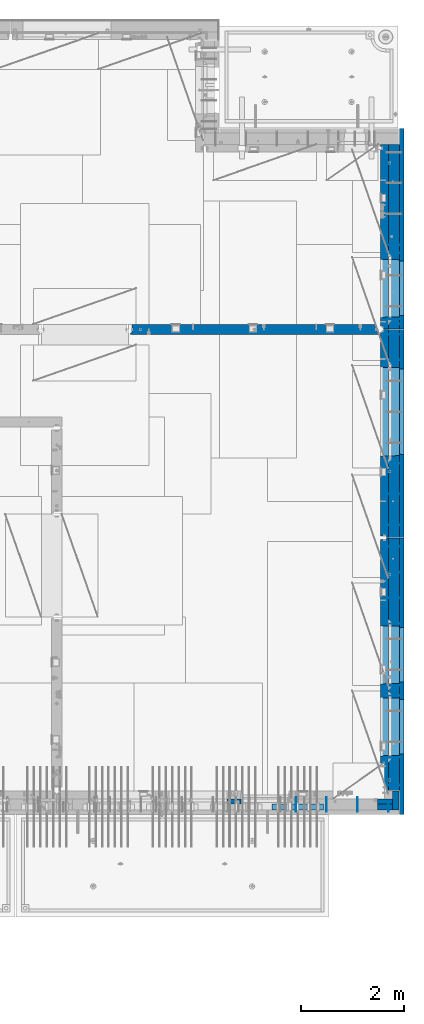
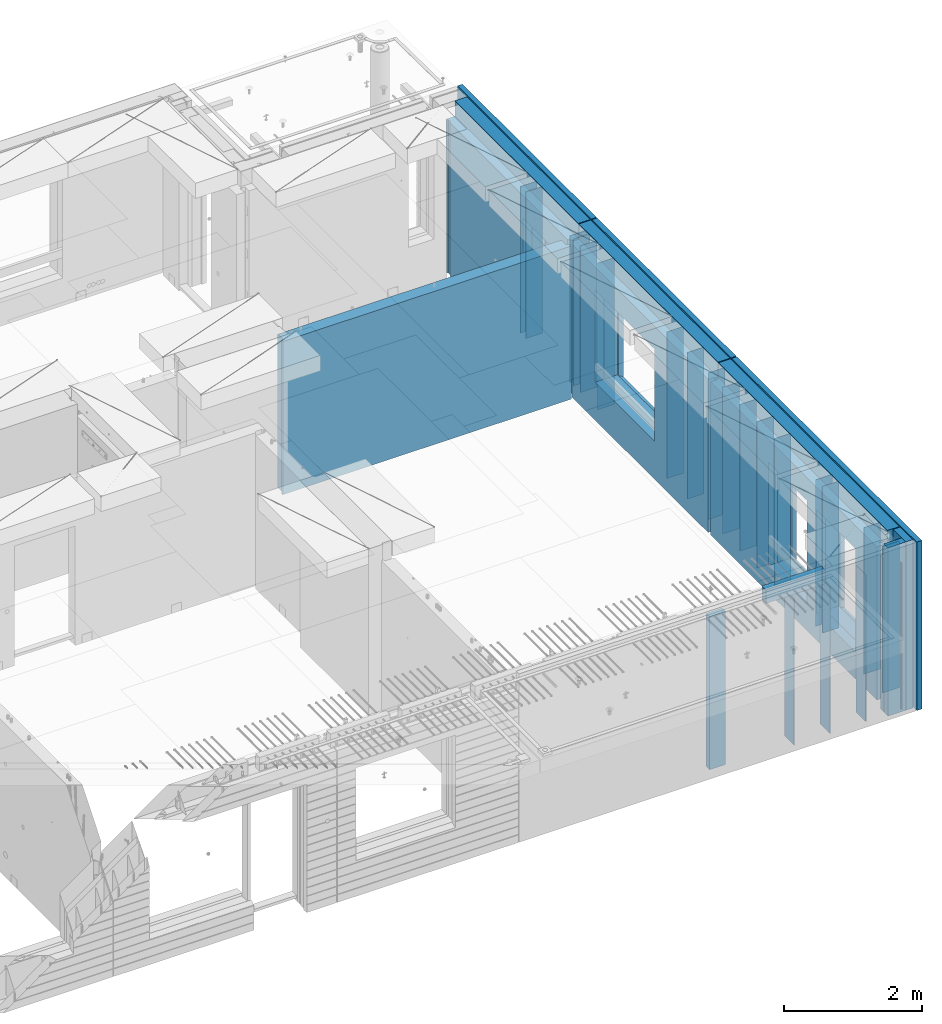
# One storey, part 233 of 341: 37 walls, 7 elements without a shape of their own.
"""IFC2X3 building model written with IfcOpenShell, lengths in millimetres."""

from ifc_helpers import new_model, si_unit, frame, origin_with_axes, place, context, subcontext, project, spatial, faceted_brep, material, type_object, element, aggregate, save


model = new_model("IFC2X3")

# Units and contexts
model_context = context("Model", 3, precision=1e-05, world=origin_with_axes())
body_context = subcontext(model_context, "Body", "Model", "MODEL_VIEW")
ifc_project = project(units=[si_unit("LENGTHUNIT", "METRE", prefix="MILLI"), si_unit("AREAUNIT", "SQUARE_METRE"), si_unit("VOLUMEUNIT", "CUBIC_METRE"), si_unit("MASSUNIT", "GRAM", prefix="KILO"), si_unit("TIMEUNIT", "SECOND"), si_unit("PLANEANGLEUNIT", "RADIAN"), si_unit("SOLIDANGLEUNIT", "STERADIAN"), si_unit("THERMODYNAMICTEMPERATUREUNIT", "DEGREE_CELSIUS"), si_unit("LUMINOUSINTENSITYUNIT", "LUMEN")], contexts=[model_context])

# Site, building, storey
site_placement = place(None, origin_with_axes())
site = spatial("IfcSite", under=ifc_project, at=site_placement, CompositionType="ELEMENT")
building_placement = place(site_placement, origin_with_axes())
building = spatial("IfcBuilding", under=site, at=building_placement, CompositionType="ELEMENT")
storey_placement = place(building_placement, origin_with_axes())
storey = spatial("IfcBuildingStorey", under=building, at=storey_placement, Name="5", CompositionType="ELEMENT", Elevation=0.0)

# Assembly, walls
assembly_1_placement = place(storey_placement, origin_with_axes())
assembly_1 = element("IfcElementAssembly", 1, at=assembly_1_placement, inside=storey, AssemblyPlace="NOTDEFINED", PredefinedType="REINFORCEMENT_UNIT")
ifc_material_1 = material(Name="Undefined")
wall_type_1 = type_object("IfcWallType", PredefinedType="NOTDEFINED")
wall_1_placement = place(assembly_1_placement, frame((35030.0, 18465.0002441406, 95115.0), z_axis=(0.0, 0.0, 1.0), x_axis=(1.0, 0.0, 0.0)))
wall_1 = element("IfcWall", 2, at=wall_1_placement, type_object=wall_type_1, material=ifc_material_1, Name="(PD)", context=body_context, shape_type="Brep", body=[
    faceted_brep([(0.0, 5.0, -1300.0), (0.0, 5.0, 1300.0), (280.0, 5.0, 1300.0), (280.0, 5.0, -1300.0), (0.0, -5.0, 1300.0), (280.0, -5.0, 1300.0), (0.0, -5.0, -1300.0), (280.0, -5.0, -1300.0)], [[[0, 1, 2, 3]], [[1, 4, 5, 2]], [[4, 6, 7, 5]], [[6, 0, 3, 7]], [[5, 7, 3, 2]], [[6, 4, 1, 0]]]),
])
wall_2_placement = place(assembly_1_placement, frame((35030.0, 17085.0002441406, 95115.0), z_axis=(0.0, 0.0, 1.0), x_axis=(1.0, 0.0, 0.0)))
wall_2 = element("IfcWall", 3, at=wall_2_placement, type_object=wall_type_1, material=ifc_material_1, Name="(PD)", context=body_context, shape_type="Brep", body=[
    faceted_brep([(0.0, 5.0, -1300.0), (0.0, 5.0, 1300.0), (280.0, 5.0, 1300.0), (280.0, 5.0, -1300.0), (0.0, -5.0, 1300.0), (280.0, -5.0, 1300.0), (0.0, -5.0, -1300.0), (280.0, -5.0, -1300.0)], [[[0, 1, 2, 3]], [[1, 4, 5, 2]], [[4, 6, 7, 5]], [[6, 0, 3, 7]], [[5, 7, 3, 2]], [[6, 4, 1, 0]]]),
])
wall_3_placement = place(assembly_1_placement, frame((35030.0, 17185.0002441406, 95115.0), z_axis=(0.0, 0.0, 1.0), x_axis=(1.0, 0.0, 0.0)))
wall_3 = element("IfcWall", 4, at=wall_3_placement, type_object=wall_type_1, material=ifc_material_1, Name="(PD)", context=body_context, shape_type="Brep", body=[
    faceted_brep([(0.0, 5.0, -1300.0), (0.0, 5.0, 1300.0), (280.0, 5.0, 1300.0), (280.0, 5.0, -1300.0), (0.0, -5.0, 1300.0), (280.0, -5.0, 1300.0), (0.0, -5.0, -1300.0), (280.0, -5.0, -1300.0)], [[[0, 1, 2, 3]], [[1, 4, 5, 2]], [[4, 6, 7, 5]], [[6, 0, 3, 7]], [[5, 7, 3, 2]], [[6, 4, 1, 0]]]),
])
wall_4_placement = place(assembly_1_placement, frame((35030.0, 18625.0002441406, 95115.0), z_axis=(0.0, 0.0, 1.0), x_axis=(1.0, 0.0, 0.0)))
wall_4 = element("IfcWall", 5, at=wall_4_placement, type_object=wall_type_1, material=ifc_material_1, Name="(PD)", context=body_context, shape_type="Brep", body=[
    faceted_brep([(0.0, 5.0, -1300.0), (0.0, 5.0, 1300.0), (280.0, 5.0, 1300.0), (280.0, 5.0, -1300.0), (0.0, -5.0, 1300.0), (280.0, -5.0, 1300.0), (0.0, -5.0, -1300.0), (280.0, -5.0, -1300.0)], [[[0, 1, 2, 3]], [[1, 4, 5, 2]], [[4, 6, 7, 5]], [[6, 0, 3, 7]], [[5, 7, 3, 2]], [[6, 4, 1, 0]]]),
])

assembly_2_placement = place(storey_placement, origin_with_axes())
assembly_2 = element("IfcElementAssembly", 6, at=assembly_2_placement, inside=storey, AssemblyPlace="NOTDEFINED", PredefinedType="REINFORCEMENT_UNIT")
wall_5_placement = place(assembly_2_placement, frame((35060.0, 7780.0, 95115.0), z_axis=(0.0, 0.0, 1.0), x_axis=(0.0, -1.0, 0.0)))
wall_5 = element("IfcWall", 7, at=wall_5_placement, type_object=wall_type_1, material=ifc_material_1, Name="(PD)", context=body_context, shape_type="Brep", body=[
    faceted_brep([(0.0, 5.0, -1300.0), (0.0, 5.0, 1300.0), (180.0, 5.0, 1300.0), (180.0, 5.0, -1300.0), (0.0, -5.0, 1300.0), (180.0, -5.0, 1300.0), (0.0, -5.0, -1300.0), (180.0, -5.0, -1300.0)], [[[0, 1, 2, 3]], [[1, 4, 5, 2]], [[4, 6, 7, 5]], [[6, 0, 3, 7]], [[5, 7, 3, 2]], [[6, 4, 1, 0]]]),
])
wall_6_placement = place(assembly_2_placement, frame((34460.0, 7880.0, 95115.0), z_axis=(0.0, 0.0, 1.0), x_axis=(0.0, -1.0, 0.0)))
wall_6 = element("IfcWall", 8, at=wall_6_placement, type_object=wall_type_1, material=ifc_material_1, Name="(PD)", context=body_context, shape_type="Brep", body=[
    faceted_brep([(0.0, 5.0, -1300.0), (0.0, 5.0, 1300.0), (280.0, 5.0, 1300.0), (280.0, 5.0, -1300.0), (0.0, -5.0, 1300.0), (280.0, -5.0, 1300.0), (0.0, -5.0, -1300.0), (280.0, -5.0, -1300.0)], [[[0, 1, 2, 3]], [[1, 4, 5, 2]], [[4, 6, 7, 5]], [[6, 0, 3, 7]], [[5, 7, 3, 2]], [[6, 4, 1, 0]]]),
])
wall_7_placement = place(assembly_2_placement, frame((33860.0, 7880.0, 95115.0), z_axis=(0.0, 0.0, 1.0), x_axis=(0.0, -1.0, 0.0)))
wall_7 = element("IfcWall", 9, at=wall_7_placement, type_object=wall_type_1, material=ifc_material_1, Name="(PD)", context=body_context, shape_type="Brep", body=[
    faceted_brep([(0.0, 5.0, -1300.0), (0.0, 5.0, 1300.0), (280.0, 5.0, 1300.0), (280.0, 5.0, -1300.0), (0.0, -5.0, 1300.0), (280.0, -5.0, 1300.0), (0.0, -5.0, -1300.0), (280.0, -5.0, -1300.0)], [[[0, 1, 2, 3]], [[1, 4, 5, 2]], [[4, 6, 7, 5]], [[6, 0, 3, 7]], [[5, 7, 3, 2]], [[6, 4, 1, 0]]]),
])

assembly_3_placement = place(storey_placement, origin_with_axes())
assembly_3 = element("IfcElementAssembly", 10, at=assembly_3_placement, inside=storey, AssemblyPlace="NOTDEFINED", PredefinedType="REINFORCEMENT_UNIT")
wall_8_placement = place(assembly_3_placement, frame((35030.0, 12755.0002861023, 95115.0), z_axis=(0.0, 0.0, 1.0), x_axis=(1.0, 0.0, 0.0)))
wall_8 = element("IfcWall", 11, at=wall_8_placement, type_object=wall_type_1, material=ifc_material_1, Name="(PD)", context=body_context, shape_type="Brep", body=[
    faceted_brep([(0.0, 5.0, -1300.0), (0.0, 5.0, 1300.0), (280.0, 5.0, 1300.0), (280.0, 5.0, -1300.0), (0.0, -5.0, 1300.0), (280.0, -5.0, 1300.0), (0.0, -5.0, -1300.0), (280.0, -5.0, -1300.0)], [[[0, 1, 2, 3]], [[1, 4, 5, 2]], [[4, 6, 7, 5]], [[6, 0, 3, 7]], [[5, 7, 3, 2]], [[6, 4, 1, 0]]]),
])
wall_9_placement = place(assembly_3_placement, frame((35030.0, 12255.0002861023, 95115.0), z_axis=(0.0, 0.0, 1.0), x_axis=(1.0, 0.0, 0.0)))
wall_9 = element("IfcWall", 12, at=wall_9_placement, type_object=wall_type_1, material=ifc_material_1, Name="(PD)", context=body_context, shape_type="Brep", body=[
    faceted_brep([(0.0, 5.0, -1300.0), (0.0, 5.0, 1300.0), (280.0, 5.0, 1300.0), (280.0, 5.0, -1300.0), (0.0, -5.0, 1300.0), (280.0, -5.0, 1300.0), (0.0, -5.0, -1300.0), (280.0, -5.0, -1300.0)], [[[0, 1, 2, 3]], [[1, 4, 5, 2]], [[4, 6, 7, 5]], [[6, 0, 3, 7]], [[5, 7, 3, 2]], [[6, 4, 1, 0]]]),
])
wall_10_placement = place(assembly_3_placement, frame((35030.0, 11755.0002861023, 95115.0), z_axis=(0.0, 0.0, 1.0), x_axis=(1.0, 0.0, 0.0)))
wall_10 = element("IfcWall", 13, at=wall_10_placement, type_object=wall_type_1, material=ifc_material_1, Name="(PD)", context=body_context, shape_type="Brep", body=[
    faceted_brep([(0.0, 5.0, -1300.0), (0.0, 5.0, 1300.0), (280.0, 5.0, 1300.0), (280.0, 5.0, -1300.0), (0.0, -5.0, 1300.0), (280.0, -5.0, 1300.0), (0.0, -5.0, -1300.0), (280.0, -5.0, -1300.0)], [[[0, 1, 2, 3]], [[1, 4, 5, 2]], [[4, 6, 7, 5]], [[6, 0, 3, 7]], [[5, 7, 3, 2]], [[6, 4, 1, 0]]]),
])
wall_11_placement = place(assembly_3_placement, frame((35030.0, 11255.0002861023, 95115.0), z_axis=(0.0, 0.0, 1.0), x_axis=(1.0, 0.0, 0.0)))
wall_11 = element("IfcWall", 14, at=wall_11_placement, type_object=wall_type_1, material=ifc_material_1, Name="(PD)", context=body_context, shape_type="Brep", body=[
    faceted_brep([(0.0, 5.0, -1300.0), (0.0, 5.0, 1300.0), (280.0, 5.0, 1300.0), (280.0, 5.0, -1300.0), (0.0, -5.0, 1300.0), (280.0, -5.0, 1300.0), (0.0, -5.0, -1300.0), (280.0, -5.0, -1300.0)], [[[0, 1, 2, 3]], [[1, 4, 5, 2]], [[4, 6, 7, 5]], [[6, 0, 3, 7]], [[5, 7, 3, 2]], [[6, 4, 1, 0]]]),
])
wall_12_placement = place(assembly_3_placement, frame((35030.0, 8105.0, 95115.0), z_axis=(0.0, 0.0, 1.0), x_axis=(1.0, 0.0, 0.0)))
wall_12 = element("IfcWall", 15, at=wall_12_placement, type_object=wall_type_1, material=ifc_material_1, Name="(PD)", context=body_context, shape_type="Brep", body=[
    faceted_brep([(0.0, 5.0, -1300.0), (0.0, 5.0, 1300.0), (280.0, 5.0, 1300.0), (280.0, 5.0, -1300.0), (0.0, -5.0, 1300.0), (280.0, -5.0, 1300.0), (0.0, -5.0, -1300.0), (280.0, -5.0, -1300.0)], [[[0, 1, 2, 3]], [[1, 4, 5, 2]], [[4, 6, 7, 5]], [[6, 0, 3, 7]], [[5, 7, 3, 2]], [[6, 4, 1, 0]]]),
])
wall_13_placement = place(assembly_3_placement, frame((35030.0, 8115.0, 95115.0), z_axis=(0.0, 0.0, 1.0), x_axis=(1.0, 0.0, 0.0)))
wall_13 = element("IfcWall", 16, at=wall_13_placement, type_object=wall_type_1, material=ifc_material_1, Name="(PD)", context=body_context, shape_type="Brep", body=[
    faceted_brep([(0.0, 5.0, -1300.0), (0.0, 5.0, 1300.0), (280.0, 5.0, 1300.0), (280.0, 5.0, -1300.0), (0.0, -5.0, 1300.0), (280.0, -5.0, 1300.0), (0.0, -5.0, -1300.0), (280.0, -5.0, -1300.0)], [[[0, 1, 2, 3]], [[1, 4, 5, 2]], [[4, 6, 7, 5]], [[6, 0, 3, 7]], [[5, 7, 3, 2]], [[6, 4, 1, 0]]]),
])
wall_14_placement = place(assembly_3_placement, frame((35030.0, 9855.00028610229, 95115.0), z_axis=(0.0, 0.0, 1.0), x_axis=(1.0, 0.0, 0.0)))
wall_14 = element("IfcWall", 17, at=wall_14_placement, type_object=wall_type_1, material=ifc_material_1, Name="(PD)", context=body_context, shape_type="Brep", body=[
    faceted_brep([(0.0, 5.0, -1300.0), (0.0, 5.0, 1300.0), (280.0, 5.0, 1300.0), (280.0, 5.0, -1300.0), (0.0, -5.0, 1300.0), (280.0, -5.0, 1300.0), (0.0, -5.0, -1300.0), (280.0, -5.0, -1300.0)], [[[0, 1, 2, 3]], [[1, 4, 5, 2]], [[4, 6, 7, 5]], [[6, 0, 3, 7]], [[5, 7, 3, 2]], [[6, 4, 1, 0]]]),
])
wall_15_placement = place(assembly_3_placement, frame((35030.0, 10055.0002861023, 95115.0), z_axis=(0.0, 0.0, 1.0), x_axis=(1.0, 0.0, 0.0)))
wall_15 = element("IfcWall", 18, at=wall_15_placement, type_object=wall_type_1, material=ifc_material_1, Name="(PD)", context=body_context, shape_type="Brep", body=[
    faceted_brep([(0.0, 5.0, -1300.0), (0.0, 5.0, 1300.0), (280.0, 5.0, 1300.0), (280.0, 5.0, -1300.0), (0.0, -5.0, 1300.0), (280.0, -5.0, 1300.0), (0.0, -5.0, -1300.0), (280.0, -5.0, -1300.0)], [[[0, 1, 2, 3]], [[1, 4, 5, 2]], [[4, 6, 7, 5]], [[6, 0, 3, 7]], [[5, 7, 3, 2]], [[6, 4, 1, 0]]]),
])

assembly_4_placement = place(storey_placement, origin_with_axes())
assembly_4 = element("IfcElementAssembly", 19, at=assembly_4_placement, inside=storey, AssemblyPlace="NOTDEFINED", PredefinedType="REINFORCEMENT_UNIT")
wall_16_placement = place(assembly_4_placement, frame((35030.0, 13175.0002861023, 95115.0), z_axis=(0.0, 0.0, 1.0), x_axis=(1.0, 0.0, 0.0)))
wall_16 = element("IfcWall", 20, at=wall_16_placement, type_object=wall_type_1, material=ifc_material_1, Name="(PD)", context=body_context, shape_type="Brep", body=[
    faceted_brep([(0.0, 5.0, -1300.0), (0.0, 5.0, 1300.0), (280.0, 5.0, 1300.0), (280.0, 5.0, -1300.0), (0.0, -5.0, 1300.0), (280.0, -5.0, 1300.0), (0.0, -5.0, -1300.0), (280.0, -5.0, -1300.0)], [[[0, 1, 2, 3]], [[1, 4, 5, 2]], [[4, 6, 7, 5]], [[6, 0, 3, 7]], [[5, 7, 3, 2]], [[6, 4, 1, 0]]]),
])
wall_17_placement = place(assembly_4_placement, frame((35030.0, 13775.0002861023, 95115.0), z_axis=(0.0, 0.0, 1.0), x_axis=(1.0, 0.0, 0.0)))
wall_17 = element("IfcWall", 21, at=wall_17_placement, type_object=wall_type_1, material=ifc_material_1, Name="(PD)", context=body_context, shape_type="Brep", body=[
    faceted_brep([(0.0, 5.0, -1300.0), (0.0, 5.0, 1300.0), (280.0, 5.0, 1300.0), (280.0, 5.0, -1300.0), (0.0, -5.0, 1300.0), (280.0, -5.0, 1300.0), (0.0, -5.0, -1300.0), (280.0, -5.0, -1300.0)], [[[0, 1, 2, 3]], [[1, 4, 5, 2]], [[4, 6, 7, 5]], [[6, 0, 3, 7]], [[5, 7, 3, 2]], [[6, 4, 1, 0]]]),
])
wall_18_placement = place(assembly_4_placement, frame((35030.0, 16885.0002861023, 95115.0), z_axis=(0.0, 0.0, 1.0), x_axis=(1.0, 0.0, 0.0)))
wall_18 = element("IfcWall", 22, at=wall_18_placement, type_object=wall_type_1, material=ifc_material_1, Name="(PD)", context=body_context, shape_type="Brep", body=[
    faceted_brep([(0.0, 5.0, -1300.0), (0.0, 5.0, 1300.0), (280.0, 5.0, 1300.0), (280.0, 5.0, -1300.0), (0.0, -5.0, 1300.0), (280.0, -5.0, 1300.0), (0.0, -5.0, -1300.0), (280.0, -5.0, -1300.0)], [[[0, 1, 2, 3]], [[1, 4, 5, 2]], [[4, 6, 7, 5]], [[6, 0, 3, 7]], [[5, 7, 3, 2]], [[6, 4, 1, 0]]]),
])
wall_19_placement = place(assembly_4_placement, frame((35030.0, 16385.0002861023, 95115.0), z_axis=(0.0, 0.0, 1.0), x_axis=(1.0, 0.0, 0.0)))
wall_19 = element("IfcWall", 23, at=wall_19_placement, type_object=wall_type_1, material=ifc_material_1, Name="(PD)", context=body_context, shape_type="Brep", body=[
    faceted_brep([(0.0, 5.0, -1300.0), (0.0, 5.0, 1300.0), (280.0, 5.0, 1300.0), (280.0, 5.0, -1300.0), (0.0, -5.0, 1300.0), (280.0, -5.0, 1300.0), (0.0, -5.0, -1300.0), (280.0, -5.0, -1300.0)], [[[0, 1, 2, 3]], [[1, 4, 5, 2]], [[4, 6, 7, 5]], [[6, 0, 3, 7]], [[5, 7, 3, 2]], [[6, 4, 1, 0]]]),
])

# Wall
wall_20_placement = place(assembly_2_placement, frame((33260.0, 7880.0, 95115.0), z_axis=(0.0, 0.0, 1.0), x_axis=(0.0, -1.0, 0.0)))
wall_20 = element("IfcWall", 24, at=wall_20_placement, type_object=wall_type_1, material=ifc_material_1, Name="(PD)", context=body_context, shape_type="Brep", body=[
    faceted_brep([(0.0, 5.0, -1300.0), (0.0, 5.0, 1300.0), (280.0, 5.0, 1300.0), (280.0, 5.0, -1300.0), (0.0, -5.0, 1300.0), (280.0, -5.0, 1300.0), (0.0, -5.0, -1300.0), (280.0, -5.0, -1300.0)], [[[0, 1, 2, 3]], [[1, 4, 5, 2]], [[4, 6, 7, 5]], [[6, 0, 3, 7]], [[5, 7, 3, 2]], [[6, 4, 1, 0]]]),
])

wall_21_placement = place(assembly_3_placement, frame((35030.0, 8655.0, 95115.0), z_axis=(0.0, 0.0, 1.0), x_axis=(1.0, 0.0, 0.0)))
wall_21 = element("IfcWall", 25, at=wall_21_placement, type_object=wall_type_1, material=ifc_material_1, Name="(PD)", context=body_context, shape_type="Brep", body=[
    faceted_brep([(0.0, 5.0, -1300.0), (0.0, 5.0, 1300.0), (280.0, 5.0, 1300.0), (280.0, 5.0, -1300.0), (0.0, -5.0, 1300.0), (280.0, -5.0, 1300.0), (0.0, -5.0, -1300.0), (280.0, -5.0, -1300.0)], [[[0, 1, 2, 3]], [[1, 4, 5, 2]], [[4, 6, 7, 5]], [[6, 0, 3, 7]], [[5, 7, 3, 2]], [[6, 4, 1, 0]]]),
])

wall_22_placement = place(assembly_4_placement, frame((35030.0, 14375.0002861023, 95115.0), z_axis=(0.0, 0.0, 1.0), x_axis=(1.0, 0.0, 0.0)))
wall_22 = element("IfcWall", 26, at=wall_22_placement, type_object=wall_type_1, material=ifc_material_1, Name="(PD)", context=body_context, shape_type="Brep", body=[
    faceted_brep([(0.0, 5.0, -1300.0), (0.0, 5.0, 1300.0), (280.0, 5.0, 1300.0), (280.0, 5.0, -1300.0), (0.0, -5.0, 1300.0), (280.0, -5.0, 1300.0), (0.0, -5.0, -1300.0), (280.0, -5.0, -1300.0)], [[[0, 1, 2, 3]], [[1, 4, 5, 2]], [[4, 6, 7, 5]], [[6, 0, 3, 7]], [[5, 7, 3, 2]], [[6, 4, 1, 0]]]),
])

# Assembly, wall
assembly_5_placement = place(storey_placement, origin_with_axes())
assembly_5 = element("IfcElementAssembly", 27, at=assembly_5_placement, inside=storey, AssemblyPlace="NOTDEFINED", PredefinedType="REINFORCEMENT_UNIT")
ifc_material_2 = material(Name="CONCRETE/C25/30")
wall_type_2 = type_object("IfcWallType", PredefinedType="NOTDEFINED")
wall_23_placement = place(assembly_5_placement, frame((30040.0, 16980.0002441406, 95112.5), z_axis=(0.0, 0.0, 1.0), x_axis=(1.0, 0.0, 0.0)))
wall_23 = element("IfcWall", 28, at=wall_23_placement, type_object=wall_type_2, material=ifc_material_2, context=body_context, shape_type="Brep", body=[
    faceted_brep([(4785.0, 100.0, 1357.5), (4785.0, -30.0, 1357.5), (4785.0, -30.0, -1357.5), (4785.0, 100.0, -1357.5), (4840.0, -60.0, 1357.5), (4840.0, -60.0, -1357.5), (30.0003214753524, 100.0, 1357.5), (30.0003214753524, 100.0, -1357.5), (30.0003214753524, -57.0, -1357.5), (30.0003214753524, -57.0, 1357.5), (0.0, -70.0001393059865, -1357.5), (0.0, -70.0001393059865, 1357.5), (0.0, -100.0, -1357.5), (0.0, -100.0, 1357.5), (4840.0, -100.0, -1357.5), (4840.0, -100.0, 1357.5)], [[[0, 1, 2, 3]], [[4, 5, 2, 1]], [[6, 7, 8, 9]], [[9, 8, 10, 11]], [[12, 13, 11, 10]], [[13, 12, 14, 15]], [[0, 6, 9, 11, 13, 15, 4, 1]], [[7, 6, 0, 3]], [[14, 12, 10, 8, 7, 3, 2, 5]], [[15, 14, 5, 4]]]),
])
aggregate(assembly_5, [wall_23])

# Assemblies, wall
assembly_6_placement = place(storey_placement, origin_with_axes())
assembly_6 = element("IfcElementAssembly", 29, at=assembly_6_placement, inside=storey, AssemblyPlace="NOTDEFINED", PredefinedType="REINFORCEMENT_UNIT")
assembly_7_placement = place(assembly_6_placement, origin_with_axes())
assembly_7 = element("IfcElementAssembly", 30, at=assembly_7_placement, Name="Steel Assembly", AssemblyPlace="NOTDEFINED", PredefinedType="NOTDEFINED")
aggregate(assembly_6, [assembly_7])
ifc_material_3 = material()
wall_type_3 = type_object("IfcWallType", PredefinedType="NOTDEFINED")
wall_24_placement = place(assembly_7_placement, frame((32799.9998568133, 7690.00021946163, 96590.0), z_axis=(0.0, 0.0, 1.0), x_axis=(1.0, 0.0, 0.0)))
wall_24 = element("IfcWall", 31, at=wall_24_placement, type_object=wall_type_3, material=ifc_material_3, context=body_context, shape_type="Brep", body=[
    faceted_brep([(0.0, 60.0, -120.0), (0.0, 60.0, 120.0), (1000.0, 60.0, 120.0), (1000.0, 60.0, -120.0), (0.0, -60.0, 120.0), (1000.0, -60.0, 120.0), (0.0, -60.0, -120.0), (1000.0, -60.0, -120.0)], [[[0, 1, 2, 3]], [[1, 4, 5, 2]], [[4, 6, 7, 5]], [[6, 0, 3, 7]], [[5, 7, 3, 2]], [[6, 4, 1, 0]]]),
])
aggregate(assembly_7, [wall_24])

# Wall
ifc_material_4 = material(Name="COS5gt")
wall_type_4 = type_object("IfcWallType", PredefinedType="NOTDEFINED")
wall_25_placement = place(assembly_1_placement, frame((35170.0, 20575.0002441406, 95247.5), z_axis=(0.0, 0.0, 1.0), x_axis=(0.0, -1.0, 0.0)))
wall_25 = element("IfcWall", 32, at=wall_25_placement, type_object=wall_type_4, material=ifc_material_4, context=body_context, shape_type="Brep", body=[
    faceted_brep([(0.0, 90.0, 1492.5), (3585.0, 90.0, 1492.5), (3585.0, 90.0, 1442.5), (0.0, 90.0, 1442.5), (0.0, -110.0, 1492.5), (3585.0, -110.0, 1492.5), (3585.0, 110.0, 1442.5), (3585.0, -110.0, -1492.5), (3585.0, 90.0, -1492.5), (3585.0, 90.0, -1442.5), (3585.0, 110.0, -1442.5), (0.0, 110.0, 1442.5), (0.0, 90.0, -1492.5), (0.0, -110.0, -1492.5), (0.0, 110.0, -1442.5), (0.0, 90.0, -1442.5), (2239.99987343476, 110.0, -807.5), (2269.99987343476, 110.0, -807.5), (3319.99987343476, 110.0, -807.5), (3349.99987343476, 110.0, -807.5), (3349.99987343476, 110.0, -802.5), (3349.99987343476, 110.0, 807.5), (2239.99987343476, 110.0, 807.5), (2239.99987343476, 110.0, -802.5), (3355.94581938071, -110.0, -813.445945945947), (3355.94581938071, -110.0, 813.445945945947), (2234.05392748882, -110.0, -813.445945945947), (2234.05392748882, -110.0, 813.445945945947)], [[[0, 1, 2, 3]], [[4, 5, 1, 0]], [[6, 2, 1, 5, 7, 8, 9, 10]], [[11, 3, 2, 6]], [[12, 13, 4, 0, 3, 11, 14, 15]], [[7, 13, 12, 8]], [[15, 9, 8, 12]], [[14, 10, 9, 15]], [[11, 6, 10, 14], [16, 17, 18, 19, 20, 21, 22, 23]], [[20, 19, 24, 25, 21]], [[18, 17, 16, 26, 24, 19]], [[23, 22, 27, 26, 16]], [[21, 25, 27, 22]], [[4, 13, 7, 5], [24, 26, 27, 25]]]),
])

wall_26_placement = place(assembly_3_placement, frame((35170.0, 12920.0002861023, 95247.5), z_axis=(0.0, 0.0, 1.0), x_axis=(0.0, -1.0, 0.0)))
wall_26 = element("IfcWall", 33, at=wall_26_placement, type_object=wall_type_4, material=ifc_material_4, context=body_context, shape_type="Brep", body=[
    faceted_brep([(0.0, 90.0, 1492.5), (4905.00028610229, 90.0, 1492.5), (4905.00028610229, 90.0, 1442.5), (-0.25, 90.0, 1442.5), (0.0, -110.0, 1492.5), (4905.00028610229, -110.0, 1492.5), (4905.00028610229, 110.0, 1442.5), (4905.00028610229, -110.0, -1492.5), (4905.00028610229, 90.0, -1492.5), (4905.00028610229, 90.0, -1442.5), (4905.00028610229, 110.0, -1442.5), (-0.25, 110.0, 1442.5), (0.0, 90.0, -1492.5), (0.0, -110.0, -1492.5), (-0.25, 110.0, -1442.5), (-0.25, 90.0, -1442.5), (3115.00024333302, 110.0, -1007.5), (3145.00024333302, 110.0, -1007.5), (4195.00024333302, 110.0, -1007.5), (4225.00024333302, 110.0, -1007.5), (4225.00024333302, 110.0, -1002.5), (4225.00024333302, 110.0, 807.5), (3115.00024333302, 110.0, 807.5), (3115.00024333302, 110.0, -1002.5), (1715.00062480275, 110.0, -1007.5), (1745.00062480275, 110.0, -1007.5), (2795.00062480275, 110.0, -1007.5), (2825.00062480275, 110.0, -1007.5), (2825.00062480275, 110.0, -1002.5), (2825.00062480275, 110.0, 807.5), (1715.00062480275, 110.0, 807.5), (1715.00062480275, 110.0, -1002.5), (4230.94618927897, -110.0, -1013.44594594595), (4230.94618927897, -110.0, 813.445945945947), (3109.05429738708, -110.0, -1013.44594594595), (3109.05429738708, -110.0, 813.445945945947), (2830.9465707487, -110.0, -1013.44594594595), (1709.0546788568, -110.0, -1013.44594594595), (1709.0546788568, -110.0, 813.445945945947), (2830.9465707487, -110.0, 813.445945945947)], [[[0, 1, 2, 3]], [[4, 5, 1, 0]], [[6, 2, 1, 5, 7, 8, 9, 10]], [[11, 3, 2, 6]], [[12, 13, 4, 0, 3, 11, 14, 15]], [[7, 13, 12, 8]], [[15, 9, 8, 12]], [[14, 10, 9, 15]], [[11, 6, 10, 14], [16, 17, 18, 19, 20, 21, 22, 23], [24, 25, 26, 27, 28, 29, 30, 31]], [[20, 19, 32, 33, 21]], [[18, 17, 16, 34, 32, 19]], [[23, 22, 35, 34, 16]], [[21, 33, 35, 22]], [[4, 13, 7, 5], [32, 34, 35, 33], [36, 37, 38, 39]], [[26, 25, 24, 37, 36, 27]], [[31, 30, 38, 37, 24]], [[29, 39, 38, 30]], [[28, 27, 36, 39, 29]]]),
])

wall_27_placement = place(assembly_4_placement, frame((35170.0, 16980.0002861023, 95247.5), z_axis=(0.0, 0.0, 1.0), x_axis=(0.0, -1.0, 0.0)))
wall_27 = element("IfcWall", 34, at=wall_27_placement, type_object=wall_type_4, material=ifc_material_4, context=body_context, shape_type="Brep", body=[
    faceted_brep([(1409.0, 90.0, -1492.5), (1409.0, 90.0, -1442.5), (4045.0, 90.0, -1442.5), (4045.0, 90.0, -1492.5), (5.0, 110.0, -1492.5), (5.0, -110.0, -1492.5), (5.0, -110.0, 1492.5), (5.00004196166992, 90.0, 1492.5), (5.00004196166992, 90.0, 1442.5), (5.00004196166992, 110.0, 1442.5), (4045.0, -110.0, -1492.5), (4045.0, -110.0, 1492.5), (2460.94588410319, -110.0, -813.445945945947), (739.053992211293, -110.0, -813.445945945947), (739.053992211293, -110.0, 813.445945945947), (2460.94588410319, -110.0, 813.445945945947), (2454.99993815724, 110.0, 807.5), (744.99993815724, 110.0, 807.5), (2454.99993815724, 110.0, -802.5), (2454.99993815724, 110.0, -807.5), (2424.99993815724, 110.0, -807.5), (774.99993815724, 110.0, -807.5), (744.99993815724, 110.0, -807.5), (744.99993815724, 110.0, -802.5), (4045.0, 110.0, 1442.5), (4045.0, 110.0, -1442.5), (1409.0, 110.0, -1442.5), (1409.0, 110.0, -1492.5), (4045.0, 90.0, 1442.5), (4045.0, 90.0, 1492.5)], [[[0, 1, 2, 3]], [[4, 5, 6, 7, 8, 9]], [[6, 5, 10, 11], [12, 13, 14, 15]], [[16, 15, 14, 17]], [[18, 19, 12, 15, 16]], [[20, 21, 22, 13, 12, 19]], [[23, 17, 14, 13, 22]], [[4, 9, 24, 25, 26, 27], [22, 21, 20, 19, 18, 16, 17, 23]], [[3, 10, 5, 4, 27, 0]], [[26, 1, 0, 27]], [[25, 2, 1, 26]], [[24, 28, 29, 11, 10, 3, 2, 25]], [[9, 8, 28, 24]], [[7, 29, 28, 8]], [[6, 11, 29, 7]]]),
])

ifc_material_5 = material(Name="CONCRETE/C30/37")
wall_type_5 = type_object("IfcWallType", PredefinedType="NOTDEFINED")
wall_28_placement = place(assembly_1_placement, frame((35322.5, 20432.0002441406, 95247.5), z_axis=(0.0, 0.0, 1.0), x_axis=(0.0, -1.0, 0.0)))
wall_28 = element("IfcWall", 35, at=wall_28_placement, type_object=wall_type_5, material=ifc_material_5, context=body_context, shape_type="Brep", body=[
    faceted_brep([(-453.0, -42.5, -1492.5), (-453.0, -42.5, 1492.5), (-453.0, 42.5, 1492.5), (-453.0, 42.5, -1492.5), (3442.0, 42.5, -1492.5), (3442.0, -42.5, -1492.5), (3442.0, -42.5, 1492.5), (3176.99987343476, -42.5, 782.5), (3176.99987343476, -42.5, -807.5), (2126.99987343476, -42.5, -807.5), (2126.99987343476, -42.5, 782.5), (2126.99987343476, -42.5, 787.5), (3176.99987343476, -42.5, 787.5), (2126.99987343476, 42.5, 782.5), (3176.99987343476, 42.5, 782.5), (3186.99987343476, 42.5, 782.5), (2116.99987343476, 42.5, 782.5), (3186.99987343476, 42.5, -857.5), (2116.99987343476, 42.5, -857.5), (3442.0, 42.5, 1492.5)], [[[0, 1, 2, 3]], [[0, 3, 4, 5]], [[1, 0, 5, 6], [7, 8, 9, 10, 11, 12]], [[13, 14, 15, 12, 11, 16]], [[17, 8, 7, 12, 15]], [[18, 9, 8, 17]], [[16, 11, 10, 9, 18]], [[3, 2, 19, 4], [17, 15, 14, 13, 16, 18]], [[6, 5, 4, 19]], [[2, 1, 6, 19]]]),
])

wall_29_placement = place(assembly_3_placement, frame((35322.5, 12920.2502861023, 95247.5), z_axis=(0.0, 0.0, 1.0), x_axis=(0.0, -1.0, 0.0)))
wall_29 = element("IfcWall", 36, at=wall_29_placement, type_object=wall_type_5, material=ifc_material_5, context=body_context, shape_type="Brep", body=[
    faceted_brep([(0.0, 42.5, 1492.5), (0.0, -42.5, 1492.5), (5375.25028610229, -42.5, 1492.5), (5375.25028610229, 42.5, 1492.5), (0.0, -42.5, -1492.5), (0.0, 42.5, -1492.5), (5375.25028610229, 42.5, -1492.5), (5375.25028610229, -42.5, -1492.5), (4205.25024333302, 42.5, -1057.5), (4195.25024333302, -42.5, -1007.5), (4195.25024333302, -42.5, 782.5), (4195.25024333302, -42.5, 787.5), (4205.25024333302, 42.5, 782.5), (3135.25024333302, 42.5, -1057.5), (3145.25024333302, -42.5, -1007.5), (3135.25024333302, 42.5, 782.5), (3145.25024333302, -42.5, 787.5), (3145.25024333302, -42.5, 782.5), (3145.25024333302, 42.5, 782.5), (4195.25024333302, 42.5, 782.5), (2795.25062480275, -42.5, 782.5), (2795.25062480275, -42.5, -1007.5), (1745.25062480275, -42.5, -1007.5), (1745.25062480275, -42.5, 782.5), (1745.25062480275, -42.5, 787.5), (2795.25062480275, -42.5, 787.5), (1745.25062480275, 42.5, 782.5), (2795.25062480275, 42.5, 782.5), (2805.25062480275, 42.5, 782.5), (1735.25062480275, 42.5, 782.5), (2805.25062480275, 42.5, -1057.5), (1735.25062480275, 42.5, -1057.5)], [[[0, 1, 2, 3]], [[4, 5, 6, 7]], [[2, 7, 6, 3]], [[8, 9, 10, 11, 12]], [[13, 14, 9, 8]], [[15, 16, 17, 14, 13]], [[18, 19, 12, 11, 16, 15]], [[1, 4, 7, 2], [20, 21, 22, 23, 24, 25], [10, 9, 14, 17, 16, 11]], [[26, 27, 28, 25, 24, 29]], [[30, 21, 20, 25, 28]], [[31, 22, 21, 30]], [[29, 24, 23, 22, 31]], [[5, 0, 3, 6], [30, 28, 27, 26, 29, 31], [8, 12, 19, 18, 15, 13]], [[4, 1, 0, 5]]]),
])

wall_30_placement = place(assembly_4_placement, frame((35322.5, 16980.0002861023, 95247.5), z_axis=(0.0, 0.0, 1.0), x_axis=(0.0, -1.0, 0.0)))
wall_30 = element("IfcWall", 37, at=wall_30_placement, type_object=wall_type_5, material=ifc_material_5, context=body_context, shape_type="Brep", body=[
    faceted_brep([(5.00004196166992, 42.5, 1492.5), (5.00004196166992, -42.5, 1492.5), (4045.0, -42.5, 1492.5), (4045.0, 42.5, 1492.5), (5.00004196166992, -42.5, -1492.5), (5.00004196166992, 42.5, -1492.5), (4045.0, 42.5, -1492.5), (4045.0, -42.5, -1492.5), (2424.99993815724, -42.5, 782.5), (2424.99993815724, -42.5, 781.785034179688), (2424.99993815724, -42.5, -807.5), (774.99993815724, -42.5, -807.5), (774.99993815724, -42.5, 781.785034179688), (774.99993815724, -42.5, 782.5), (774.99993815724, -42.5, 787.5), (2424.99993815724, -42.5, 787.5), (774.99993815724, 42.5, 782.5), (2424.99993815724, 42.5, 782.5), (2434.99993815724, 42.5, 782.5), (764.99993815724, 42.5, 782.5), (2434.99993815724, 42.5, -857.5), (764.99993815724, 42.5, -857.5)], [[[0, 1, 2, 3]], [[4, 5, 6, 7]], [[2, 7, 6, 3]], [[1, 4, 7, 2], [8, 9, 10, 11, 12, 13, 14, 15]], [[16, 17, 18, 15, 14, 19]], [[20, 10, 9, 8, 15, 18]], [[21, 11, 10, 20]], [[19, 14, 13, 12, 11, 21]], [[5, 0, 3, 6], [20, 18, 17, 16, 19, 21]], [[4, 1, 0, 5]]]),
])

wall_type_6 = type_object("IfcWallType", PredefinedType="NOTDEFINED")
wall_31_placement = place(assembly_1_placement, frame((34985.0, 20575.0002441406, 95112.5), z_axis=(0.0, 0.0, 1.0), x_axis=(0.0, -1.0, 0.0)))
wall_31 = element("IfcWall", 38, at=wall_31_placement, type_object=wall_type_6, material=ifc_material_2, context=body_context, shape_type="Brep", body=[
    faceted_brep([(0.0, 75.0, -1357.5), (0.0, 75.0, 1357.5), (3585.0, 75.0, 1357.5), (3585.0, 75.0, -1357.5), (3355.94581938071, 75.0, -678.445945945947), (3355.94581938071, 75.0, 948.445945945947), (2234.05392748882, 75.0, 948.445945945947), (2234.05392748882, 75.0, -678.445945945947), (0.0, -75.0, -1357.5), (0.0, -75.0, 1357.5), (30.0050569130617, -75.0, -1357.5), (30.0050569130617, -75.0, 1357.5), (43.0050569130617, -55.0, -1357.5), (43.0050569130617, -55.0, 1357.5), (97.0050569130617, -55.0, -1357.5), (97.0050569130617, -55.0, 1357.5), (110.005056913062, -75.0, -1357.5), (110.005056913062, -75.0, 1357.5), (3525.0, -75.0, 1357.5), (3585.0, -15.0, 1357.5), (3585.0, -15.0, -1357.5), (3525.0, -75.0, -1357.5), (3359.99987343476, -75.0, -682.5), (2229.99987343476, -75.0, -682.5), (2229.99987343476, -75.0, 952.5), (3359.99987343476, -75.0, 952.5)], [[[0, 1, 2, 3], [4, 5, 6, 7]], [[8, 9, 1, 0]], [[9, 8, 10, 11]], [[11, 10, 12, 13]], [[13, 12, 14, 15]], [[15, 14, 16, 17]], [[2, 1, 9, 11, 13, 15, 17, 18, 19]], [[3, 2, 19, 20]], [[16, 14, 12, 10, 8, 0, 3, 20, 21]], [[19, 18, 21, 20]], [[17, 16, 21, 18], [22, 23, 24, 25]], [[6, 24, 23, 7]], [[5, 25, 24, 6]], [[4, 22, 25, 5]], [[7, 23, 22, 4]]]),
])

aggregate(assembly_1, [wall_1, wall_2, wall_3, wall_4, wall_28, wall_25, wall_31])

wall_32_placement = place(assembly_3_placement, frame((34985.0, 12920.0002861023, 95112.5), z_axis=(0.0, 0.0, 1.0), x_axis=(0.0, -1.0, 0.0)))
wall_32 = element("IfcWall", 39, at=wall_32_placement, type_object=wall_type_6, material=ifc_material_2, context=body_context, shape_type="Brep", body=[
    faceted_brep([(4855.00028610229, -75.0, 1357.5), (4855.00028610229, -75.0, -1357.5), (4855.00028610229, 32.0000069488524, -1357.5), (4855.00028610229, 32.0000069488524, 1357.5), (4905.00028610229, 45.0000069488524, 1357.5), (4905.00028610229, 45.0000069488524, -1357.5), (29.9999989126591, 32.0000004547946, 1357.5), (29.9999989126591, 32.0000004547946, -1357.5), (30.0000016637459, -75.0, -1357.5), (30.0000016637459, -75.0, 1357.5), (0.0, 45.0, 1357.5), (0.0, 45.0, -1357.5), (0.0, 75.0, 1357.5), (0.0, 75.0, -1357.5), (4905.00028610229, 75.0, -1357.5), (4905.00028610229, 75.0, 1357.5), (4230.94618927897, 75.0, 948.445945945947), (4235.00024333302, -75.0, 952.5), (3105.00024333302, -75.0, 952.5), (3109.05429738708, 75.0, 948.445945945947), (4230.94618927897, 75.0, -878.445945945947), (4235.00024333302, -75.0, -882.5), (3109.05429738708, 75.0, -878.445945945947), (3105.00024333302, -75.0, -882.5), (2830.9465707487, 75.0, -878.445945945947), (2830.9465707487, 75.0, 948.445945945947), (1709.0546788568, 75.0, 948.445945945947), (1709.0546788568, 75.0, -878.445945945947), (2835.00062480275, -75.0, -882.5), (2835.00062480275, -75.0, 952.5), (1705.00062480275, -75.0, -882.5), (1705.00062480275, -75.0, 952.5)], [[[0, 1, 2, 3]], [[4, 3, 2, 5]], [[6, 7, 8, 9]], [[10, 11, 7, 6]], [[12, 13, 11, 10]], [[1, 8, 7, 11, 13, 14, 5, 2]], [[14, 15, 4, 5]], [[16, 17, 18, 19]], [[20, 21, 17, 16]], [[22, 23, 21, 20]], [[19, 18, 23, 22]], [[13, 12, 15, 14], [20, 16, 19, 22], [24, 25, 26, 27]], [[24, 28, 29, 25]], [[27, 30, 28, 24]], [[26, 31, 30, 27]], [[25, 29, 31, 26]], [[9, 8, 1, 0], [28, 30, 31, 29], [21, 23, 18, 17]], [[15, 12, 10, 6, 9, 0, 3, 4]]]),
])

aggregate(assembly_3, [wall_8, wall_9, wall_10, wall_11, wall_12, wall_13, wall_14, wall_15, wall_21, wall_29, wall_26, wall_32])

wall_33_placement = place(assembly_4_placement, frame((34985.0, 16980.0002861023, 95112.5), z_axis=(0.0, 0.0, 1.0), x_axis=(0.0, -1.0, 0.0)))
wall_33 = element("IfcWall", 40, at=wall_33_placement, type_object=wall_type_6, material=ifc_material_2, context=body_context, shape_type="Brep", body=[
    faceted_brep([(5.0, 75.0, -1357.5), (5.0, 75.0, 1357.5), (4045.0, 75.0, 1357.5), (4045.0, 75.0, -1357.5), (2460.94588410319, 75.0, -678.445945945947), (2460.94588410319, 75.0, 948.445945945947), (739.053992211293, 75.0, 948.445945945947), (739.053992211293, 75.0, -678.445945945947), (5.0, -15.0000022791291, -1357.5), (5.0, -15.0000022791291, 1357.5), (65.0, -75.0, 1357.5), (65.0, -75.0, -1357.5), (4015.0, -75.0, 1357.5), (4015.0, 32.0, 1357.5), (4045.0, 45.0, 1357.5), (4045.0, 45.0, -1357.5), (4015.0, -75.0, -1357.5), (4015.0, 32.0, -1357.5), (2464.99993815724, -75.0, -682.5), (734.99993815724, -75.0, -682.5), (734.99993815724, -75.0, 952.5), (2464.99993815724, -75.0, 952.5)], [[[0, 1, 2, 3], [4, 5, 6, 7]], [[1, 0, 8, 9]], [[10, 9, 8, 11]], [[2, 1, 9, 10, 12, 13, 14]], [[3, 2, 14, 15]], [[16, 11, 8, 0, 3, 15, 17]], [[14, 13, 17, 15]], [[12, 16, 17, 13]], [[10, 11, 16, 12], [18, 19, 20, 21]], [[6, 20, 19, 7]], [[5, 21, 20, 6]], [[4, 18, 21, 5]], [[7, 19, 18, 4]]]),
])

aggregate(assembly_4, [wall_16, wall_17, wall_18, wall_19, wall_22, wall_27, wall_30, wall_33])

ifc_material_6 = material(Name="CONCRETE/C35/45")
wall_type_7 = type_object("IfcWallType", PredefinedType="NOTDEFINED")
wall_34_placement = place(assembly_2_placement, frame((35145.0000381475, 7800.0, 95112.5), z_axis=(0.0, 0.0, 1.0), x_axis=(-1.0, 3.00000001838171e-08, 0.0)))
wall_34 = element("IfcWall", 41, at=wall_34_placement, type_object=wall_type_7, material=ifc_material_6, context=body_context, shape_type="Brep", body=[
    faceted_brep([(0.0, 50.0, -1357.5), (0.0, 50.0, 1357.5), (300.001908754726, 50.0, 1357.5), (300.001908754726, 50.0, -1357.5), (0.0, -50.0, 1357.5), (300.001908754726, -50.0, 1357.5), (0.0, -50.0, -1357.5), (300.001908754726, -50.0, -1357.5)], [[[0, 1, 2, 3]], [[1, 4, 5, 2]], [[4, 6, 7, 5]], [[6, 0, 3, 7]], [[5, 7, 3, 2]], [[6, 4, 1, 0]]]),
])

wall_35_placement = place(assembly_2_placement, frame((32195.0000381475, 7800.0, 95112.5), z_axis=(0.0, 0.0, 1.0), x_axis=(-1.0, 3.00000001838171e-08, 0.0)))
wall_35 = element("IfcWall", 42, at=wall_35_placement, type_object=wall_type_7, material=ifc_material_6, context=body_context, shape_type="Brep", body=[
    faceted_brep([(0.0, 50.0, -1357.5), (0.0, 50.0, 1357.5), (270.001908754726, 50.0, 1357.5), (270.001908754726, 50.0, -1357.5), (0.0, -50.0, 1357.5), (270.001908754726, -50.0, 1357.5), (0.0, -50.0, -1357.5), (270.001908754726, -50.0, -1357.5)], [[[0, 1, 2, 3]], [[1, 4, 5, 2]], [[4, 6, 7, 5]], [[6, 0, 3, 7]], [[5, 7, 3, 2]], [[6, 4, 1, 0]]]),
])

ifc_material_7 = material(Name="SPU")
wall_type_8 = type_object("IfcWallType", PredefinedType="NOTDEFINED")
wall_36_placement = place(assembly_2_placement, frame((35145.0000381475, 7690.0, 95247.5), z_axis=(0.0, 0.0, 1.0), x_axis=(-1.0, 3.00000001838171e-08, 0.0)))
wall_36 = element("IfcWall", 43, at=wall_36_placement, type_object=wall_type_8, material=ifc_material_7, context=body_context, shape_type="Brep", body=[
    faceted_brep([(0.0, 60.0, -1492.5), (0.0, 60.0, 1492.5), (300.001908754726, 60.0, 1492.5), (300.001908754726, 60.0, -1492.5), (0.0, -60.0, 1492.5), (300.001908754726, -60.0, 1492.5), (0.0, -60.0, -1492.5), (300.001908754726, -60.0, -1492.5)], [[[0, 1, 2, 3]], [[1, 4, 5, 2]], [[4, 6, 7, 5]], [[6, 0, 3, 7]], [[5, 7, 3, 2]], [[6, 4, 1, 0]]]),
])

wall_37_placement = place(assembly_2_placement, frame((35205.0, 8000.0, 95247.5), z_axis=(0.0, 0.0, 1.0), x_axis=(0.0, -1.0, 0.0)))
wall_37 = element("IfcWall", 44, at=wall_37_placement, type_object=wall_type_8, material=ifc_material_7, context=body_context, shape_type="Brep", body=[
    faceted_brep([(0.0, 60.0, -1492.5), (0.0, 60.0, 1492.5), (370.0, 60.0, 1492.5), (370.0, 60.0, -1492.5), (0.0, -60.0, 1492.5), (370.0, -60.0, 1492.5), (0.0, -60.0, -1492.5), (370.0, -60.0, -1492.5)], [[[0, 1, 2, 3]], [[1, 4, 5, 2]], [[4, 6, 7, 5]], [[6, 0, 3, 7]], [[5, 7, 3, 2]], [[6, 4, 1, 0]]]),
])

aggregate(assembly_2, [wall_36, wall_34, wall_5, wall_6, wall_7, wall_37, wall_20, wall_35])

save(model, "model.ifc")
